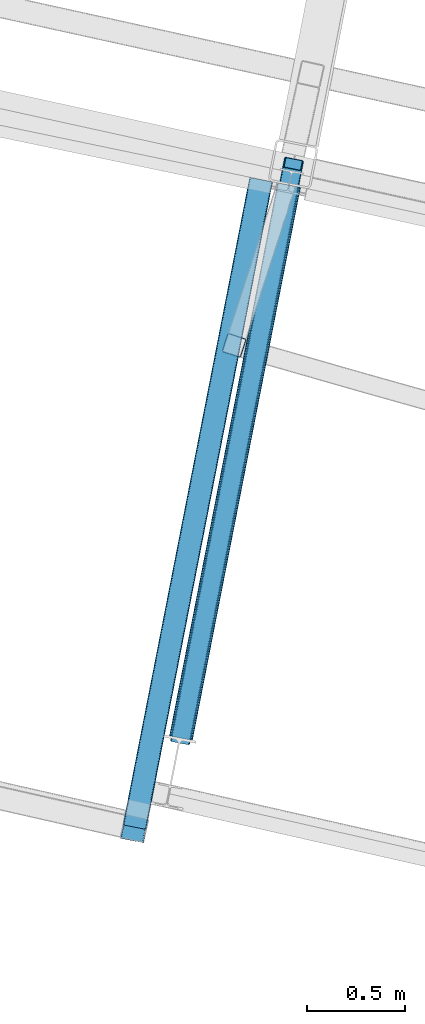
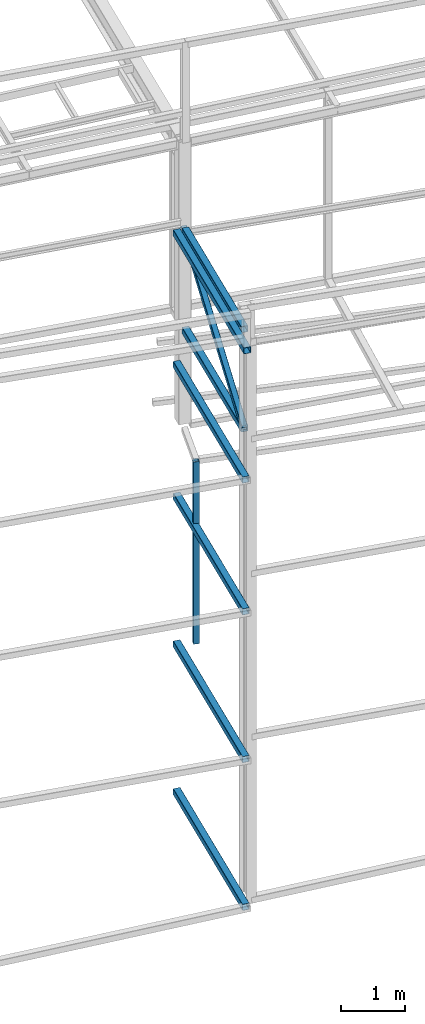
# One storey, part 21 of 215: 8 beams, 1 member, 9 elements without a shape of their own.
"""IFC2X3 building model written with IfcOpenShell, lengths in millimetres."""

from ifc_helpers import new_model, si_unit, frame, origin_with_axes, origin_2d_with_axis, place, context, subcontext, project, spatial, hollow_rectangle, extrude, material, type_object, element, aggregate, save


model = new_model("IFC2X3")

# Units and contexts
model_context = context("Model", 3, precision=1e-05, world=origin_with_axes())
body_context = subcontext(model_context, "Body", "Model", "MODEL_VIEW")
ifc_project = project(units=[si_unit("LENGTHUNIT", "METRE", prefix="MILLI"), si_unit("AREAUNIT", "SQUARE_METRE"), si_unit("VOLUMEUNIT", "CUBIC_METRE"), si_unit("MASSUNIT", "GRAM", prefix="KILO"), si_unit("TIMEUNIT", "SECOND"), si_unit("PLANEANGLEUNIT", "RADIAN"), si_unit("SOLIDANGLEUNIT", "STERADIAN"), si_unit("THERMODYNAMICTEMPERATUREUNIT", "DEGREE_CELSIUS"), si_unit("LUMINOUSINTENSITYUNIT", "LUMEN")], contexts=[model_context])

# Site, building, storey
site_placement = place(None, origin_with_axes())
site = spatial("IfcSite", under=ifc_project, at=site_placement, CompositionType="ELEMENT")
building_placement = place(site_placement, origin_with_axes())
building = spatial("IfcBuilding", under=site, at=building_placement, Name="Undefined", CompositionType="ELEMENT")
storey_placement = place(building_placement, origin_with_axes())
storey = spatial("IfcBuildingStorey", under=building, at=storey_placement, Name="Undefined", CompositionType="ELEMENT", Elevation=0.0)

# Assembly, beam
assembly_1_placement = place(storey_placement, origin_with_axes())
assembly_1 = element("IfcElementAssembly", 1, at=assembly_1_placement, inside=storey, Name="Steel Assembly", AssemblyPlace="NOTDEFINED", PredefinedType="RIGID_FRAME")
ifc_material = material(Name="STEEL/S275JR")
beam_type_1 = type_object("IfcBeamType", PredefinedType="NOTDEFINED")
beam_1_placement = place(assembly_1_placement, frame((44747.7263043085, 9268.88263368137, 6760.00000147429), z_axis=(-0.950969035847311, 0.30928610195034, 0.0), x_axis=(0.0, 0.0, -1.0)))
beam_1 = element("IfcBeam", 2, at=beam_1_placement, type_object=beam_type_1, material=ifc_material, Name="MONTANT", context=body_context, shape_type="SweptSolid", body=[
    extrude(hollow_rectangle(XDim=100.0, YDim=100.0, WallThickness=4.0, InnerFilletRadius=4.0, OuterFilletRadius=8.0, at=origin_2d_with_axis()), frame((3499.99999998675, 0.0, 0.0), z_axis=(-1.0, 0.0, 0.0), x_axis=(-6.93889390390723e-18, -1.0, -3.46944695195361e-18)), (0.0, 0.0, 1.0), 3500.0),
])
aggregate(assembly_1, [beam_1])

assembly_2_placement = place(storey_placement, origin_with_axes())
assembly_2 = element("IfcElementAssembly", 3, at=assembly_2_placement, inside=storey, Name="Steel Assembly", AssemblyPlace="NOTDEFINED", PredefinedType="RIGID_FRAME")
beam_type_2 = type_object("IfcBeamType", PredefinedType="NOTDEFINED")
beam_2_placement = place(assembly_2_placement, frame((44884.7477461113, 10111.6411732232, -160.391045426908), z_axis=(0.981422412076285, -0.191859451014913, -1.1429000000881e-05), x_axis=(-0.191859451027258, -0.981422412139429, -1.39400000020158e-06)))
beam_2 = element("IfcBeam", 4, at=beam_2_placement, type_object=beam_type_2, material=ifc_material, Name="LISSE", context=body_context, shape_type="SweptSolid", body=[
    extrude(hollow_rectangle(XDim=120.0, YDim=120.0, WallThickness=5.0, InnerFilletRadius=5.0, OuterFilletRadius=10.0, at=origin_2d_with_axis()), frame((3356.18088592598, -2.84231308282977e-14, 2.54398341465813e-13), z_axis=(-1.0, 0.0, 0.0), x_axis=(-6.93889390390723e-18, -1.0, -3.46944695195361e-18)), (0.0, 0.0, 1.0), 3356.2),
])
aggregate(assembly_2, [beam_2])

assembly_3_placement = place(storey_placement, origin_with_axes())
assembly_3 = element("IfcElementAssembly", 5, at=assembly_3_placement, inside=storey, Name="Steel Assembly", AssemblyPlace="NOTDEFINED", PredefinedType="RIGID_FRAME")
beam_3_placement = place(assembly_3_placement, frame((44884.3795589083, 10111.7245827987, 2677.30635313861), z_axis=(0.981422412076285, -0.191859451014913, -1.1429000000881e-05), x_axis=(-0.191859451027258, -0.981422412139429, -1.39400000020158e-06)))
beam_3 = element("IfcBeam", 6, at=beam_3_placement, type_object=beam_type_2, material=ifc_material, Name="LISSE", context=body_context, shape_type="SweptSolid", body=[
    extrude(hollow_rectangle(XDim=120.0, YDim=120.0, WallThickness=5.0, InnerFilletRadius=5.0, OuterFilletRadius=10.0, at=origin_2d_with_axis()), frame((3356.18088592598, -2.84231308282977e-14, 2.54398341465813e-13), z_axis=(-1.0, 0.0, 0.0), x_axis=(-6.93889390390723e-18, -1.0, -3.46944695195361e-18)), (0.0, 0.0, 1.0), 3356.2),
])
aggregate(assembly_3, [beam_3])

assembly_4_placement = place(storey_placement, origin_with_axes())
assembly_4 = element("IfcElementAssembly", 7, at=assembly_4_placement, inside=storey, Name="Steel Assembly", AssemblyPlace="NOTDEFINED", PredefinedType="RIGID_FRAME")
beam_4_placement = place(assembly_4_placement, frame((44884.3795577952, 10111.7245779062, 8046.32514983521), z_axis=(0.981422412076285, -0.191859451014913, -1.1429000000881e-05), x_axis=(-0.191859451027258, -0.981422412139429, -1.39400000020158e-06)))
beam_4 = element("IfcBeam", 8, at=beam_4_placement, type_object=beam_type_2, material=ifc_material, Name="LISSE", context=body_context, shape_type="SweptSolid", body=[
    extrude(hollow_rectangle(XDim=120.0, YDim=120.0, WallThickness=5.0, InnerFilletRadius=5.0, OuterFilletRadius=10.0, at=origin_2d_with_axis()), frame((3356.18088592598, -2.84231308282977e-14, 2.54398341465813e-13), z_axis=(-1.0, 0.0, 0.0), x_axis=(-6.93889390390723e-18, -1.0, -3.46944695195361e-18)), (0.0, 0.0, 1.0), 3356.2),
])
aggregate(assembly_4, [beam_4])

assembly_5_placement = place(storey_placement, origin_with_axes())
assembly_5 = element("IfcElementAssembly", 9, at=assembly_5_placement, inside=storey, Name="Steel Assembly", AssemblyPlace="NOTDEFINED", PredefinedType="RIGID_FRAME")
beam_5_placement = place(assembly_5_placement, frame((44884.3778995544, 10111.7251141907, 10574.6977080657), z_axis=(0.981422412076285, -0.191859451014913, -1.1429000000881e-05), x_axis=(-0.191859451027258, -0.981422412139429, -1.39400000020158e-06)))
beam_5 = element("IfcBeam", 10, at=beam_5_placement, type_object=beam_type_2, material=ifc_material, Name="LISSE", context=body_context, shape_type="SweptSolid", body=[
    extrude(hollow_rectangle(XDim=120.0, YDim=120.0, WallThickness=5.0, InnerFilletRadius=5.0, OuterFilletRadius=10.0, at=origin_2d_with_axis()), frame((3425.933598296, 1.8189886780762e-12, 1.64597221871337e-13), z_axis=(-1.0, 0.0, 0.0), x_axis=(-6.93889390390723e-18, -1.0, -3.46944695195361e-18)), (0.0, 0.0, 1.0), 3425.9),
])
aggregate(assembly_5, [beam_5])

assembly_6_placement = place(storey_placement, origin_with_axes())
assembly_6 = element("IfcElementAssembly", 11, at=assembly_6_placement, inside=storey, Name="Steel Assembly", AssemblyPlace="NOTDEFINED", PredefinedType="RIGID_FRAME")
beam_6_placement = place(assembly_6_placement, frame((44884.3795583192, 10111.7245802166, 5514.99770772753), z_axis=(0.981422412076285, -0.191859451014913, -1.1429000000881e-05), x_axis=(-0.191859451027258, -0.981422412139429, -1.39400000020158e-06)))
beam_6 = element("IfcBeam", 12, at=beam_6_placement, type_object=beam_type_2, material=ifc_material, Name="LISSE", context=body_context, shape_type="SweptSolid", body=[
    extrude(hollow_rectangle(XDim=120.0, YDim=120.0, WallThickness=5.0, InnerFilletRadius=5.0, OuterFilletRadius=10.0, at=origin_2d_with_axis()), frame((3356.18088592598, -2.84231308282977e-14, 2.54398341465813e-13), z_axis=(-1.0, 0.0, 0.0), x_axis=(-6.93889390390723e-18, -1.0, -3.46944695195361e-18)), (0.0, 0.0, 1.0), 3356.2),
])
aggregate(assembly_6, [beam_6])

assembly_7_placement = place(storey_placement, origin_with_axes())
assembly_7 = element("IfcElementAssembly", 13, at=assembly_7_placement, inside=storey, Name="Steel Assembly", AssemblyPlace="NOTDEFINED", PredefinedType="RIGID_FRAME")
beam_7_placement = place(assembly_7_placement, frame((45026.7677258624, 10084.0195784692, 8670.00002228875), z_axis=(0.0, 0.0, 1.0), x_axis=(-0.191859508000518, -0.981422401002646, -1.00000033853845e-09)))
beam_7 = element("IfcBeam", 14, at=beam_7_placement, type_object=beam_type_2, material=ifc_material, Name="POUTRE", context=body_context, shape_type="SweptSolid", body=[
    extrude(hollow_rectangle(XDim=120.0, YDim=120.0, WallThickness=5.0, InnerFilletRadius=5.0, OuterFilletRadius=10.0, at=origin_2d_with_axis()), frame((2865.93659828112, 5.49857066639268e-16, 0.0), z_axis=(-1.0, 0.0, 0.0), x_axis=(-6.93889390390723e-18, -1.0, -3.46944695195361e-18)), (0.0, 0.0, 1.0), 2865.9),
])
aggregate(assembly_7, [beam_7])

assembly_8_placement = place(storey_placement, origin_with_axes())
assembly_8 = element("IfcElementAssembly", 15, at=assembly_8_placement, inside=storey, Name="Steel Assembly", AssemblyPlace="NOTDEFINED", PredefinedType="RIGID_FRAME")
beam_8_placement = place(assembly_8_placement, frame((44476.9108118486, 7271.32515125679, 10575.3973745082), z_axis=(-0.981422412140383, 0.191859451027444, 0.0), x_axis=(0.191859470081235, 0.981422408415534, 0.0)))
beam_8 = element("IfcBeam", 16, at=beam_8_placement, type_object=beam_type_2, material=ifc_material, context=body_context, shape_type="SweptSolid", body=[
    extrude(hollow_rectangle(XDim=120.0, YDim=120.0, WallThickness=5.0, InnerFilletRadius=5.0, OuterFilletRadius=10.0, at=origin_2d_with_axis()), frame((2865.93659828112, 5.49857066639268e-16, 0.0), z_axis=(-1.0, 0.0, 0.0), x_axis=(-6.93889390390723e-18, -1.0, -3.46944695195361e-18)), (0.0, 0.0, 1.0), 2865.9),
])
aggregate(assembly_8, [beam_8])

# Assembly, member
assembly_9_placement = place(storey_placement, origin_with_axes())
assembly_9 = element("IfcElementAssembly", 17, at=assembly_9_placement, inside=storey, Name="Steel Assembly", AssemblyPlace="NOTDEFINED", PredefinedType="RIGID_FRAME")
member_type = type_object("IfcMemberType", PredefinedType="NOTDEFINED")
member_placement = place(assembly_9_placement, frame((45047.8723762899, 10191.9760215266, 10575.3995920448), z_axis=(-0.981340497267383, 0.19227685005239, -0.000664347000180921), x_axis=(-0.161578001089169, -0.826523116456124, -0.53921432429757)))
member = element("IfcMember", 18, at=member_placement, type_object=member_type, material=ifc_material, context=body_context, shape_type="SweptSolid", body=[
    extrude(hollow_rectangle(XDim=100.0, YDim=100.0, WallThickness=5.0, InnerFilletRadius=5.0, OuterFilletRadius=10.0, at=origin_2d_with_axis()), frame((3533.65903120026, -1.64941286318083e-13, -6.14907728151281e-14), z_axis=(-1.0, 0.0, 0.0), x_axis=(-6.93889390390723e-18, -1.0, -3.46944695195361e-18)), (0.0, 0.0, 1.0), 3533.7),
])
aggregate(assembly_9, [member])

save(model, "model.ifc")
